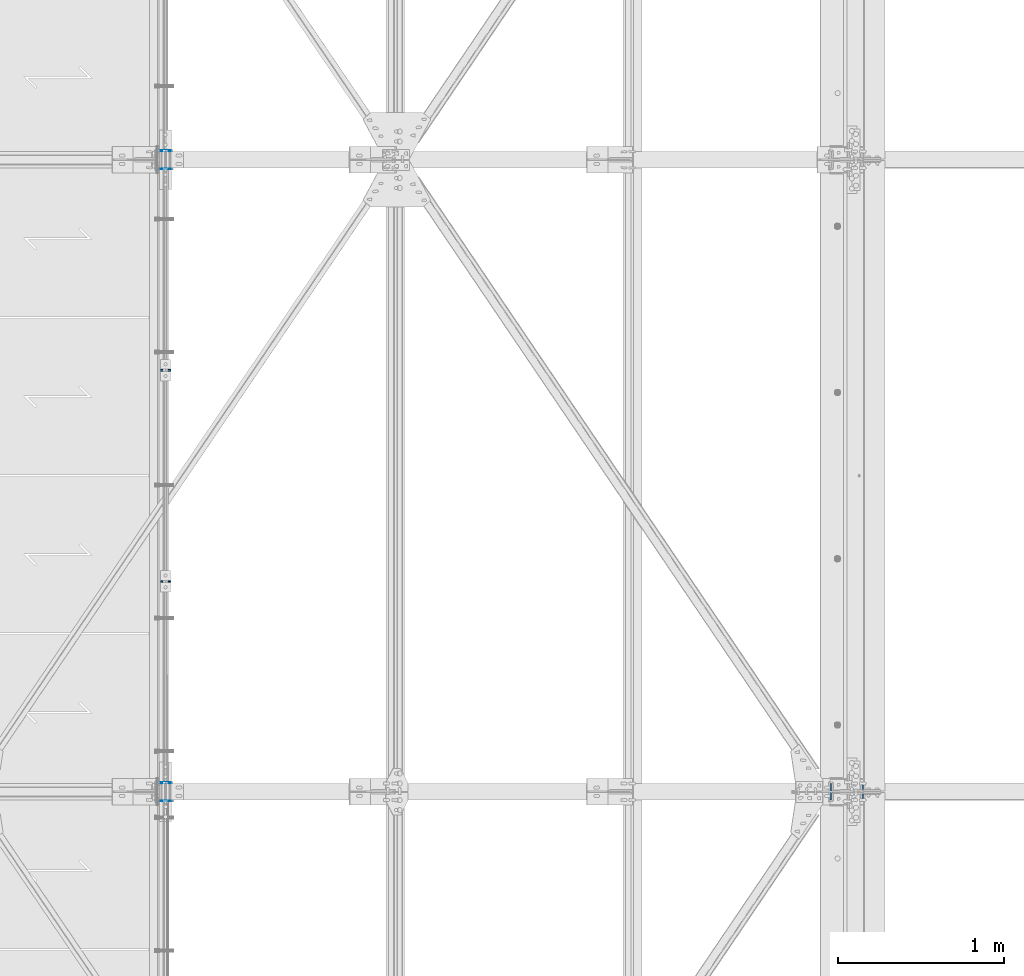
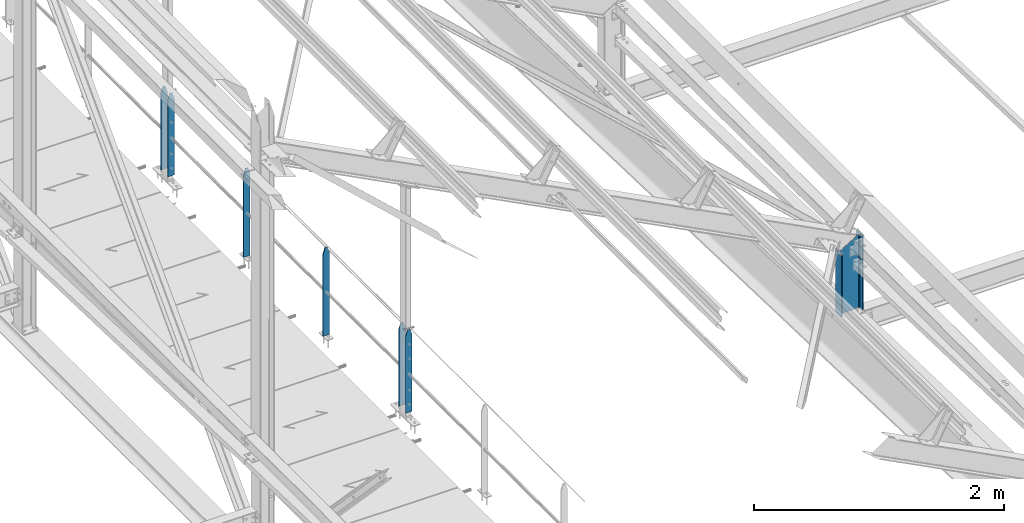
# One storey, part 32 of 496: 7 columns, 4 elements without a shape of their own.
"""IFC2X3 building model written with IfcOpenShell, lengths in millimetres."""

from ifc_helpers import new_model, si_unit, frame, origin_with_axes, origin_2d_with_axis, place, context, subcontext, project, spatial, rectangle, i_section, extrude, clip, halfspace, material, type_object, element, aggregate, save


model = new_model("IFC2X3")

# Units and contexts
model_context = context("Model", 3, precision=1e-05, world=origin_with_axes())
body_context = subcontext(model_context, "Body", "Model", "MODEL_VIEW")
ifc_project = project(units=[si_unit("LENGTHUNIT", "METRE", prefix="MILLI"), si_unit("AREAUNIT", "SQUARE_METRE"), si_unit("VOLUMEUNIT", "CUBIC_METRE"), si_unit("MASSUNIT", "GRAM", prefix="KILO"), si_unit("TIMEUNIT", "SECOND"), si_unit("PLANEANGLEUNIT", "RADIAN"), si_unit("SOLIDANGLEUNIT", "STERADIAN"), si_unit("THERMODYNAMICTEMPERATUREUNIT", "DEGREE_CELSIUS"), si_unit("LUMINOUSINTENSITYUNIT", "LUMEN")], contexts=[model_context])

# Site, building, storey
site_placement = place(None, origin_with_axes())
site = spatial("IfcSite", under=ifc_project, at=site_placement, CompositionType="ELEMENT")
building_placement = place(site_placement, origin_with_axes())
building = spatial("IfcBuilding", under=site, at=building_placement, Name="Undefined", CompositionType="ELEMENT")
storey_placement = place(building_placement, origin_with_axes())
storey = spatial("IfcBuildingStorey", under=building, at=storey_placement, Name="Undefined", CompositionType="ELEMENT", Elevation=0.0)

# Assembly, columns
assembly_1_placement = place(storey_placement, origin_with_axes())
assembly_1 = element("IfcElementAssembly", 1, at=assembly_1_placement, inside=storey, Name="MAIN COURANTE", AssemblyPlace="NOTDEFINED", PredefinedType="NOTDEFINED")
ifc_material_1 = material(Name="Undefined/S235-E24")
column_type_1 = type_object("IfcColumnType", PredefinedType="NOTDEFINED")
column_1_placement = place(assembly_1_placement, frame((24783.991604038, 8865.0034395722, 8250.00000282135), z_axis=(0.0, 0.0, 1.0), x_axis=(1.0, 0.0, 0.0)))
column_1 = element("IfcColumn", 2, at=column_1_placement, type_object=column_type_1, material=ifc_material_1, Name="MONTANT", context=body_context, shape_type="Clipping", body=[
    clip(clip(extrude(rectangle(XDim=10.0, YDim=60.0, at=origin_2d_with_axis()), frame((0.0, 0.0, 857.599997130677), z_axis=(0.0, 0.0, -1.0), x_axis=(0.0, 1.0, 0.0)), (0.0, 0.0, 1.0), 857.6), halfspace(frame((30.0000001657245, -5.000000004674, 797.599997170884), z_axis=(0.948683298050514, 0.0, 0.316227766016838), x_axis=(-0.316227766016838, 0.0, 0.948683298050514)), False)), halfspace(frame((-29.9999998342682, 4.99999999524351, 797.599997177174), z_axis=(-0.948683298050514, 0.0, 0.316227766016838), x_axis=(0.316227766016838, 0.0, 0.948683298050514)), False)),
])
column_2_placement = place(assembly_1_placement, frame((24783.9916050919, 10135.0034395722, 8250.00000195055), z_axis=(0.0, 0.0, 1.0), x_axis=(1.0, 0.0, 0.0)))
column_2 = element("IfcColumn", 3, at=column_2_placement, type_object=column_type_1, material=ifc_material_1, Name="MONTANT", context=body_context, shape_type="Clipping", body=[
    clip(clip(extrude(rectangle(XDim=10.0, YDim=60.0, at=origin_2d_with_axis()), frame((0.0, 0.0, 857.599997130677), z_axis=(0.0, 0.0, -1.0), x_axis=(0.0, 1.0, 0.0)), (0.0, 0.0, 1.0), 857.6), halfspace(frame((30.0000001657245, -5.000000004674, 797.599997170884), z_axis=(0.948683298050514, 0.0, 0.316227766016838), x_axis=(-0.316227766016838, 0.0, 0.948683298050514)), False)), halfspace(frame((-29.9999998342682, 4.99999999524351, 797.599997177174), z_axis=(-0.948683298050514, 0.0, 0.316227766016838), x_axis=(0.316227766016838, 0.0, 0.948683298050514)), False)),
])

# Assembly, column
assembly_2_placement = place(storey_placement, origin_with_axes())
assembly_2 = element("IfcElementAssembly", 4, at=assembly_2_placement, inside=storey, Name="MAIN COURANTE", AssemblyPlace="NOTDEFINED", PredefinedType="NOTDEFINED")
column_type_2 = type_object("IfcColumnType", PredefinedType="NOTDEFINED")
column_3_placement = place(assembly_2_placement, frame((24783.9916033043, 7545.00000132233, 8300.0000038009), z_axis=(0.0, 0.0, 1.0), x_axis=(1.0, 0.0, 0.0)))
column_3 = element("IfcColumn", 5, at=column_3_placement, type_object=column_type_2, material=ifc_material_1, Name="MONTANT", context=body_context, shape_type="Clipping", body=[
    clip(clip(extrude(rectangle(XDim=5.0, YDim=60.0, at=origin_2d_with_axis()), frame((0.0, 0.0, 807.599997128624), z_axis=(0.0, 0.0, -1.0), x_axis=(0.0, 1.0, 0.0)), (0.0, 0.0, 1.0), 807.6), halfspace(frame((29.9999999717475, -5.00000000468981, 747.599997131425), z_axis=(0.948683298050514, 0.0, 0.316227766016838), x_axis=(-0.316227766016838, 0.0, 0.948683298050514)), False)), halfspace(frame((-30.000000028238, 4.99999999522788, 747.599997137713), z_axis=(-0.948683298050514, 0.0, 0.316227766016838), x_axis=(0.316227766016838, 0.0, 0.948683298050514)), False)),
])
aggregate(assembly_2, [column_3])

assembly_3_placement = place(storey_placement, origin_with_axes())
assembly_3 = element("IfcElementAssembly", 6, at=assembly_3_placement, inside=storey, Name="MAIN COURANTE", AssemblyPlace="NOTDEFINED", PredefinedType="NOTDEFINED")
column_4_placement = place(assembly_3_placement, frame((24783.9916060709, 11455.000001314, 8300.00000101999), z_axis=(0.0, 0.0, 1.0), x_axis=(1.0, 0.0, 0.0)))
column_4 = element("IfcColumn", 7, at=column_4_placement, type_object=column_type_2, material=ifc_material_1, Name="MONTANT", context=body_context, shape_type="Clipping", body=[
    clip(clip(extrude(rectangle(XDim=5.0, YDim=60.0, at=origin_2d_with_axis()), frame((0.0, 0.0, 807.599997128624), z_axis=(0.0, 0.0, -1.0), x_axis=(0.0, 1.0, 0.0)), (0.0, 0.0, 1.0), 807.6), halfspace(frame((29.9999999717475, -5.00000000468981, 747.599997131425), z_axis=(0.948683298050514, 0.0, 0.316227766016838), x_axis=(-0.316227766016838, 0.0, 0.948683298050514)), False)), halfspace(frame((-30.000000028238, 4.99999999522788, 747.599997137713), z_axis=(-0.948683298050514, 0.0, 0.316227766016838), x_axis=(0.316227766016838, 0.0, 0.948683298050514)), False)),
])
aggregate(assembly_3, [column_4])

# Column
column_5_placement = place(assembly_1_placement, frame((24783.9916033855, 7655.00000131327, 8300.00000372333), z_axis=(0.0, 0.0, 1.0), x_axis=(1.0, 0.0, 0.0)))
column_5 = element("IfcColumn", 8, at=column_5_placement, type_object=column_type_2, material=ifc_material_1, Name="MONTANT", context=body_context, shape_type="Clipping", body=[
    clip(clip(extrude(rectangle(XDim=5.0, YDim=60.0, at=origin_2d_with_axis()), frame((0.0, 0.0, 807.599997128624), z_axis=(0.0, 0.0, -1.0), x_axis=(0.0, 1.0, 0.0)), (0.0, 0.0, 1.0), 807.6), halfspace(frame((29.9999999717475, -5.00000000468981, 747.599997131425), z_axis=(0.948683298050514, 0.0, 0.316227766016838), x_axis=(-0.316227766016838, 0.0, 0.948683298050514)), False)), halfspace(frame((-30.000000028238, 4.99999999522788, 747.599997137713), z_axis=(-0.948683298050514, 0.0, 0.316227766016838), x_axis=(0.316227766016838, 0.0, 0.948683298050514)), False)),
])

column_6_placement = place(assembly_1_placement, frame((24783.9916059845, 11345.0000013216, 8300.00000109652), z_axis=(0.0, 0.0, 1.0), x_axis=(1.0, 0.0, 0.0)))
column_6 = element("IfcColumn", 9, at=column_6_placement, type_object=column_type_2, material=ifc_material_1, Name="MONTANT", context=body_context, shape_type="Clipping", body=[
    clip(clip(extrude(rectangle(XDim=5.0, YDim=60.0, at=origin_2d_with_axis()), frame((0.0, 0.0, 807.599997128624), z_axis=(0.0, 0.0, -1.0), x_axis=(0.0, 1.0, 0.0)), (0.0, 0.0, 1.0), 807.6), halfspace(frame((29.9999999717475, -5.00000000468981, 747.599997131425), z_axis=(0.948683298050514, 0.0, 0.316227766016838), x_axis=(-0.316227766016838, 0.0, 0.948683298050514)), False)), halfspace(frame((-30.000000028238, 4.99999999522788, 747.599997137713), z_axis=(-0.948683298050514, 0.0, 0.316227766016838), x_axis=(0.316227766016838, 0.0, 0.948683298050514)), False)),
])

aggregate(assembly_1, [column_5, column_1, column_6, column_2])

# Assembly, column
assembly_4_placement = place(storey_placement, origin_with_axes())
assembly_4 = element("IfcElementAssembly", 10, at=assembly_4_placement, inside=storey, Name="TRAVERSE SHED", AssemblyPlace="NOTDEFINED", PredefinedType="NOTDEFINED")
ifc_material_2 = material(Name="Undefined/S275-E28")
column_type_3 = type_object("IfcColumnType", Name="IPE200", PredefinedType="NOTDEFINED")
column_7_placement = place(assembly_4_placement, frame((28880.0, 7600.0, 7811.16037857912), z_axis=(0.0, 0.0, 1.0), x_axis=(-1.0, 0.0, 0.0)))
column_7 = element("IfcColumn", 11, at=column_7_placement, type_object=column_type_3, material=ifc_material_2, Name="TRAVERSE SHED", ObjectType="IPE200", context=body_context, shape_type="Clipping", body=[
    clip(clip(extrude(i_section(OverallWidth=100.0, OverallDepth=200.0, WebThickness=5.599999905, FlangeThickness=8.5, FilletRadius=12.0, at=origin_2d_with_axis()), frame((0.0, 0.0, 741.034746750856), z_axis=(0.0, 0.0, -1.0), x_axis=(0.0, 1.0, 0.0)), (0.0, 0.0, 1.0), 794.03), halfspace(frame((-100.000000738131, 3800.0, 738.83962288747), z_axis=(0.519570377152939, 0.0, 0.854427658251506), x_axis=(0.0, 1.0, 0.0)), False)), halfspace(frame((0.0, -20.8974507473622, 9.34915825821372), z_axis=(0.0, 0.031410477145298, -0.999506569225788), x_axis=(1.0, 0.0, 0.0)), False)),
])
aggregate(assembly_4, [column_7])

save(model, "model.ifc")
